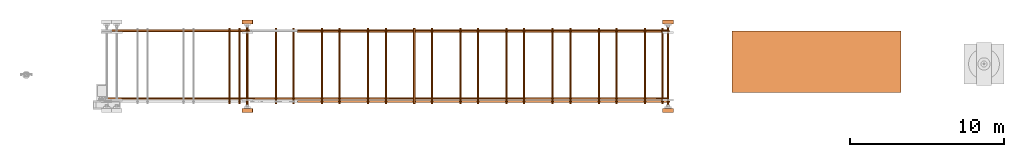
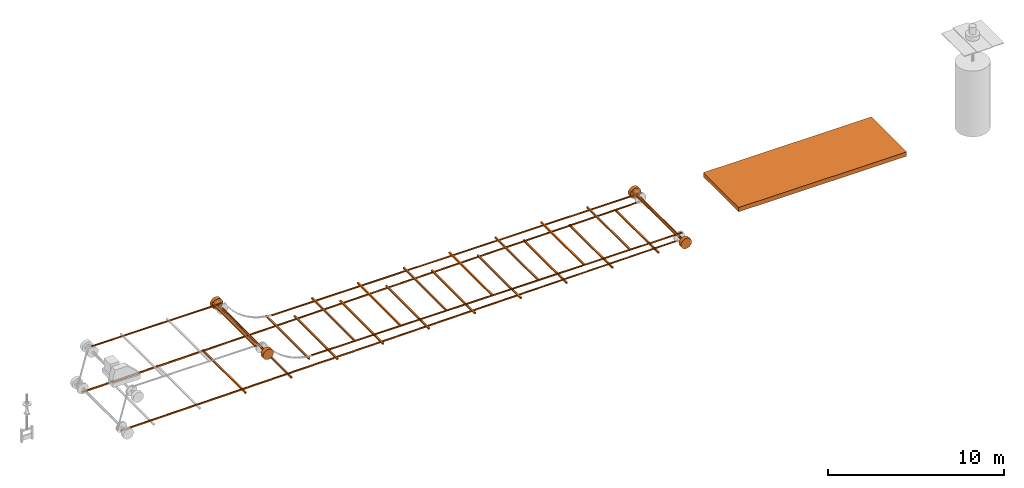
# One storey, part 2 of 6: 39 proxies.
"""IFC2X3 building model written with IfcOpenShell, lengths in millimetres."""

from ifc_helpers import new_model, entity, si_unit, converted_unit, direction, frame, origin_with_axes, origin_2d_with_axis, place, context, project, spatial, polyline, rectangle, circle, outline, extrude, source, transform, mapped, element, save


model = new_model("IFC2X3")

# Units and contexts
model_context = context("Model", 3, precision=1e-05, world=origin_with_axes(), true_north=direction((0.0, 1.0)))
ifc_project = project(units=[si_unit("LENGTHUNIT", "METRE", prefix="MILLI"), si_unit("AREAUNIT", "SQUARE_METRE"), si_unit("VOLUMEUNIT", "CUBIC_METRE"), converted_unit("PLANEANGLEUNIT", "DEGREE", entity("IfcPlaneAngleMeasure", 0.017453293), si_unit("PLANEANGLEUNIT", "RADIAN"), dimensions=[0, 0, 0, 0, 0, 0, 0]), si_unit("SOLIDANGLEUNIT", "STERADIAN"), si_unit("MASSUNIT", "GRAM"), si_unit("TIMEUNIT", "SECOND"), si_unit("THERMODYNAMICTEMPERATUREUNIT", "DEGREE_CELSIUS"), si_unit("LUMINOUSINTENSITYUNIT", "LUMEN")], contexts=[model_context])

# Site, building, storey
site_placement = place(None, origin_with_axes())
site = spatial("IfcSite", under=ifc_project, at=site_placement, CompositionType="ELEMENT")
building_placement = place(site_placement, origin_with_axes())
building = spatial("IfcBuilding", under=site, at=building_placement, Name="Default Building", CompositionType="ELEMENT")
storey_placement = place(building_placement, frame((0.0, 0.0, 16000.0), z_axis=(0.0, 0.0, 1.0), x_axis=(1.0, 0.0, 0.0)))
storey = spatial("IfcBuildingStorey", under=building, at=storey_placement, Name="3FL", CompositionType="ELEMENT", Elevation=16000.0)

# Proxies
shared_shape_1 = source(origin_with_axes(), model_context, "Body", "SweptSolid", [
    extrude(circle(Radius=350.0, at=origin_2d_with_axis()), frame((0.0, 0.0, 0.0), z_axis=(-4.43734259186819e-31, -2.95822839457879e-31, 1.0), x_axis=(1.0, 5.91669923873109e-47, 4.43734259186819e-31)), (0.0, 0.0, 1.0), 250.0),
])
proxy_1_placement = place(storey_placement, frame((52876.115417, 20861.795807, 1232.050808), z_axis=(2.22044604925031e-16, 1.0, 1.60814287233912e-16), x_axis=(4.93038065763132e-32, 1.60814287233912e-16, -1.0)))
element("IfcBuildingElementProxy", 1, at=proxy_1_placement, inside=storey, context=model_context, shape_type="MappedRepresentation", body=[
    mapped(shared_shape_1, transform((0.0, 0.0, 0.0))),
])
shared_shape_2 = source(origin_with_axes(), model_context, "Body", "SweptSolid", [
    extrude(outline(polyline([(-12108.725164, -21.26452), (12108.725164, -21.26452), (12108.725164, 21.26452), (-12108.725164, 21.26452), (-12108.725164, -21.26452)])), origin_with_axes(), (0.0, 0.0, 1.0), 100.0),
])
proxy_2_placement = place(storey_placement, frame((40886.390254, 26161.795807, 1528.900333), z_axis=(0.0, -1.0, 0.0), x_axis=(1.0, 0.0, 0.0)))
element("IfcBuildingElementProxy", 2, at=proxy_2_placement, inside=storey, context=model_context, shape_type="MappedRepresentation", body=[
    mapped(shared_shape_2, transform((0.0, 0.0, 0.0))),
])
shared_shape_3 = source(origin_with_axes(), model_context, "Body", "SweptSolid", [
    extrude(rectangle(XDim=100.0, YDim=4900.0, at=origin_2d_with_axis()), origin_with_axes(), (0.0, 0.0, 1.0), 100.0),
])
proxy_3_placement = place(storey_placement, frame((52526.115454, 23861.796014, 1582.050808), z_axis=(0.0, 0.0, 1.0), x_axis=(1.0, 0.0, 0.0)))
element("IfcBuildingElementProxy", 3, at=proxy_3_placement, inside=storey, context=model_context, shape_type="MappedRepresentation", body=[
    mapped(shared_shape_3, transform((0.0, 0.0, 0.0))),
])
shared_shape_4 = source(origin_with_axes(), model_context, "Body", "SweptSolid", [
    extrude(outline(polyline([(-18245.397829, -225.029041), (18254.602171, 190.177299), (18254.602171, 225.029041), (-18254.602171, -164.882935), (-18245.397829, -225.029041)])), origin_with_axes(), (0.0, 0.0, 1.0), 100.0),
])
proxy_4_placement = place(storey_placement, frame((34621.513247, 21811.795807, 711.550808), z_axis=(0.0, -1.0, 0.0), x_axis=(1.0, 0.0, 0.0)))
element("IfcBuildingElementProxy", 4, at=proxy_4_placement, inside=storey, context=model_context, shape_type="MappedRepresentation", body=[
    mapped(shared_shape_4, transform((0.0, 0.0, 0.0))),
])
shared_shape_5 = source(origin_with_axes(), model_context, "Body", "SweptSolid", [
    extrude(rectangle(XDim=100.0, YDim=4900.0, at=origin_2d_with_axis()), origin_with_axes(), (0.0, 0.0, 1.0), 100.0),
])
proxy_5_placement = place(storey_placement, frame((49526.115454, 23861.796014, 1582.050808), z_axis=(0.0, 0.0, 1.0), x_axis=(1.0, 0.0, 0.0)))
element("IfcBuildingElementProxy", 5, at=proxy_5_placement, inside=storey, context=model_context, shape_type="MappedRepresentation", body=[
    mapped(shared_shape_5, transform((0.0, 0.0, 0.0))),
])
shared_shape_6 = source(origin_with_axes(), model_context, "Body", "SweptSolid", [
    extrude(rectangle(XDim=100.0, YDim=4900.0, at=origin_2d_with_axis()), origin_with_axes(), (0.0, 0.0, 1.0), 100.0),
])
proxy_6_placement = place(storey_placement, frame((46526.115454, 23861.796014, 1582.050808), z_axis=(0.0, 0.0, 1.0), x_axis=(1.0, 0.0, 0.0)))
element("IfcBuildingElementProxy", 6, at=proxy_6_placement, inside=storey, context=model_context, shape_type="MappedRepresentation", body=[
    mapped(shared_shape_6, transform((0.0, 0.0, 0.0))),
])
shared_shape_7 = source(origin_with_axes(), model_context, "Body", "SweptSolid", [
    extrude(rectangle(XDim=100.0, YDim=4900.0, at=origin_2d_with_axis()), origin_with_axes(), (0.0, 0.0, 1.0), 100.0),
])
proxy_7_placement = place(storey_placement, frame((43526.115454, 23861.796014, 1582.050808), z_axis=(0.0, 0.0, 1.0), x_axis=(1.0, 0.0, 0.0)))
element("IfcBuildingElementProxy", 7, at=proxy_7_placement, inside=storey, context=model_context, shape_type="MappedRepresentation", body=[
    mapped(shared_shape_7, transform((0.0, 0.0, 0.0))),
])
shared_shape_8 = source(origin_with_axes(), model_context, "Body", "SweptSolid", [
    extrude(rectangle(XDim=100.0, YDim=4900.0, at=origin_2d_with_axis()), origin_with_axes(), (0.0, 0.0, 1.0), 100.0),
])
proxy_8_placement = place(storey_placement, frame((40526.115454, 23861.796014, 1582.050808), z_axis=(0.0, 0.0, 1.0), x_axis=(1.0, 0.0, 0.0)))
element("IfcBuildingElementProxy", 8, at=proxy_8_placement, inside=storey, context=model_context, shape_type="MappedRepresentation", body=[
    mapped(shared_shape_8, transform((0.0, 0.0, 0.0))),
])
shared_shape_9 = source(origin_with_axes(), model_context, "Body", "SweptSolid", [
    extrude(rectangle(XDim=100.0, YDim=4900.0, at=origin_2d_with_axis()), origin_with_axes(), (0.0, 0.0, 1.0), 100.0),
])
proxy_9_placement = place(storey_placement, frame((37526.115454, 23861.796014, 1582.050808), z_axis=(0.0, 0.0, 1.0), x_axis=(1.0, 0.0, 0.0)))
element("IfcBuildingElementProxy", 9, at=proxy_9_placement, inside=storey, context=model_context, shape_type="MappedRepresentation", body=[
    mapped(shared_shape_9, transform((0.0, 0.0, 0.0))),
])
shared_shape_10 = source(origin_with_axes(), model_context, "Body", "SweptSolid", [
    extrude(rectangle(XDim=100.0, YDim=4900.0, at=origin_2d_with_axis()), origin_with_axes(), (0.0, 0.0, 1.0), 100.0),
])
proxy_10_placement = place(storey_placement, frame((34526.115454, 23861.796014, 1582.050808), z_axis=(0.0, 0.0, 1.0), x_axis=(1.0, 0.0, 0.0)))
element("IfcBuildingElementProxy", 10, at=proxy_10_placement, inside=storey, context=model_context, shape_type="MappedRepresentation", body=[
    mapped(shared_shape_10, transform((0.0, 0.0, 0.0))),
])
shared_shape_11 = source(origin_with_axes(), model_context, "Body", "SweptSolid", [
    extrude(rectangle(XDim=100.0, YDim=4900.0, at=origin_2d_with_axis()), origin_with_axes(), (0.0, 0.0, 1.0), 100.0),
])
proxy_11_placement = place(storey_placement, frame((31526.115454, 23861.796014, 1582.050808), z_axis=(0.0, 0.0, 1.0), x_axis=(1.0, 0.0, 0.0)))
element("IfcBuildingElementProxy", 11, at=proxy_11_placement, inside=storey, context=model_context, shape_type="MappedRepresentation", body=[
    mapped(shared_shape_11, transform((0.0, 0.0, 0.0))),
])
shared_shape_12 = source(origin_with_axes(), model_context, "Body", "SweptSolid", [
    extrude(rectangle(XDim=100.0, YDim=4900.0, at=origin_2d_with_axis()), origin_with_axes(), (0.0, 0.0, 1.0), 100.0),
])
proxy_12_placement = place(storey_placement, frame((28526.115454, 23861.796014, 1399.050808), z_axis=(0.0, 0.0, 1.0), x_axis=(1.0, 0.0, 0.0)))
element("IfcBuildingElementProxy", 12, at=proxy_12_placement, inside=storey, context=model_context, shape_type="MappedRepresentation", body=[
    mapped(shared_shape_12, transform((0.0, 0.0, 0.0))),
])
shared_shape_13 = source(origin_with_axes(), model_context, "Body", "SweptSolid", [
    extrude(rectangle(XDim=100.0, YDim=4900.0, at=origin_2d_with_axis()), origin_with_axes(), (0.0, 0.0, 1.0), 100.0),
])
proxy_13_placement = place(storey_placement, frame((51376.115454, 23861.796014, 743.200808), z_axis=(0.0, 0.0, 1.0), x_axis=(1.0, 0.0, 0.0)))
element("IfcBuildingElementProxy", 13, at=proxy_13_placement, inside=storey, context=model_context, shape_type="MappedRepresentation", body=[
    mapped(shared_shape_13, transform((0.0, 0.0, 0.0))),
])
shared_shape_14 = source(origin_with_axes(), model_context, "Body", "SweptSolid", [
    extrude(rectangle(XDim=100.0, YDim=4900.0, at=origin_2d_with_axis()), origin_with_axes(), (0.0, 0.0, 1.0), 100.0),
])
proxy_14_placement = place(storey_placement, frame((48376.115454, 23861.796014, 743.200808), z_axis=(0.0, 0.0, 1.0), x_axis=(1.0, 0.0, 0.0)))
element("IfcBuildingElementProxy", 14, at=proxy_14_placement, inside=storey, context=model_context, shape_type="MappedRepresentation", body=[
    mapped(shared_shape_14, transform((0.0, 0.0, 0.0))),
])
shared_shape_15 = source(origin_with_axes(), model_context, "Body", "SweptSolid", [
    extrude(rectangle(XDim=100.0, YDim=4900.0, at=origin_2d_with_axis()), origin_with_axes(), (0.0, 0.0, 1.0), 100.0),
])
proxy_15_placement = place(storey_placement, frame((45376.115454, 23861.796014, 743.200808), z_axis=(0.0, 0.0, 1.0), x_axis=(1.0, 0.0, 0.0)))
element("IfcBuildingElementProxy", 15, at=proxy_15_placement, inside=storey, context=model_context, shape_type="MappedRepresentation", body=[
    mapped(shared_shape_15, transform((0.0, 0.0, 0.0))),
])
shared_shape_16 = source(origin_with_axes(), model_context, "Body", "SweptSolid", [
    extrude(rectangle(XDim=100.0, YDim=4900.0, at=origin_2d_with_axis()), origin_with_axes(), (0.0, 0.0, 1.0), 100.0),
])
proxy_16_placement = place(storey_placement, frame((42376.115454, 23861.796014, 743.200808), z_axis=(0.0, 0.0, 1.0), x_axis=(1.0, 0.0, 0.0)))
element("IfcBuildingElementProxy", 16, at=proxy_16_placement, inside=storey, context=model_context, shape_type="MappedRepresentation", body=[
    mapped(shared_shape_16, transform((0.0, 0.0, 0.0))),
])
shared_shape_17 = source(origin_with_axes(), model_context, "Body", "SweptSolid", [
    extrude(rectangle(XDim=100.0, YDim=4900.0, at=origin_2d_with_axis()), origin_with_axes(), (0.0, 0.0, 1.0), 100.0),
])
proxy_17_placement = place(storey_placement, frame((39376.115454, 23861.796014, 743.200808), z_axis=(0.0, 0.0, 1.0), x_axis=(1.0, 0.0, 0.0)))
element("IfcBuildingElementProxy", 17, at=proxy_17_placement, inside=storey, context=model_context, shape_type="MappedRepresentation", body=[
    mapped(shared_shape_17, transform((0.0, 0.0, 0.0))),
])
shared_shape_18 = source(origin_with_axes(), model_context, "Body", "SweptSolid", [
    extrude(rectangle(XDim=100.0, YDim=4900.0, at=origin_2d_with_axis()), origin_with_axes(), (0.0, 0.0, 1.0), 100.0),
])
proxy_18_placement = place(storey_placement, frame((36376.115454, 23861.796014, 743.200808), z_axis=(0.0, 0.0, 1.0), x_axis=(1.0, 0.0, 0.0)))
element("IfcBuildingElementProxy", 18, at=proxy_18_placement, inside=storey, context=model_context, shape_type="MappedRepresentation", body=[
    mapped(shared_shape_18, transform((0.0, 0.0, 0.0))),
])
shared_shape_19 = source(origin_with_axes(), model_context, "Body", "SweptSolid", [
    extrude(rectangle(XDim=100.0, YDim=4900.0, at=origin_2d_with_axis()), origin_with_axes(), (0.0, 0.0, 1.0), 100.0),
])
proxy_19_placement = place(storey_placement, frame((33376.115454, 23861.796014, 743.200808), z_axis=(0.0, 0.0, 1.0), x_axis=(1.0, 0.0, 0.0)))
element("IfcBuildingElementProxy", 19, at=proxy_19_placement, inside=storey, context=model_context, shape_type="MappedRepresentation", body=[
    mapped(shared_shape_19, transform((0.0, 0.0, 0.0))),
])
shared_shape_20 = source(origin_with_axes(), model_context, "Body", "SweptSolid", [
    extrude(rectangle(XDim=100.0, YDim=4900.0, at=origin_2d_with_axis()), origin_with_axes(), (0.0, 0.0, 1.0), 100.0),
])
proxy_20_placement = place(storey_placement, frame((25026.115454, 23861.796014, 3489.050808), z_axis=(0.0, 0.0, 1.0), x_axis=(1.0, 0.0, 0.0)))
element("IfcBuildingElementProxy", 20, at=proxy_20_placement, inside=storey, context=model_context, shape_type="MappedRepresentation", body=[
    mapped(shared_shape_20, transform((0.0, 0.0, 0.0))),
])
shared_shape_21 = source(origin_with_axes(), model_context, "Body", "SweptSolid", [
    extrude(circle(Radius=350.0, at=origin_2d_with_axis()), frame((0.0, 0.0, 0.0), z_axis=(-4.43734259186819e-31, -2.95822839457879e-31, 1.0), x_axis=(1.0, 5.91669923873109e-47, 4.43734259186819e-31)), (0.0, 0.0, 1.0), 250.0),
])
proxy_21_placement = place(storey_placement, frame((25526.115417, 20861.795807, 3139.050808), z_axis=(2.22044604925031e-16, 1.0, 1.60814287233912e-16), x_axis=(4.93038065763132e-32, 1.60814287233912e-16, -1.0)))
element("IfcBuildingElementProxy", 21, at=proxy_21_placement, inside=storey, context=model_context, shape_type="MappedRepresentation", body=[
    mapped(shared_shape_21, transform((0.0, 0.0, 0.0))),
])
shared_shape_22 = source(origin_with_axes(), model_context, "Body", "SweptSolid", [
    extrude(outline(polyline([(-12108.725164, -21.26452), (12108.725164, -21.26452), (12108.725164, 21.26452), (-12108.725164, 21.26452), (-12108.725164, -21.26452)])), origin_with_axes(), (0.0, 0.0, 1.0), 100.0),
])
proxy_22_placement = place(storey_placement, frame((40886.390254, 21611.795807, 1528.900333), z_axis=(0.0, -1.0, 0.0), x_axis=(1.0, 0.0, 0.0)))
element("IfcBuildingElementProxy", 22, at=proxy_22_placement, inside=storey, context=model_context, shape_type="MappedRepresentation", body=[
    mapped(shared_shape_22, transform((0.0, 0.0, 0.0))),
])
shared_shape_23 = source(origin_with_axes(), model_context, "Body", "SweptSolid", [
    extrude(outline(polyline([(-18245.397829, -225.029041), (18254.602171, 190.177299), (18254.602171, 225.029041), (-18254.602171, -164.882935), (-18245.397829, -225.029041)])), origin_with_axes(), (0.0, 0.0, 1.0), 100.0),
])
proxy_23_placement = place(storey_placement, frame((34621.513247, 26211.795807, 711.550808), z_axis=(0.0, -1.0, 0.0), x_axis=(1.0, 0.0, 0.0)))
element("IfcBuildingElementProxy", 23, at=proxy_23_placement, inside=storey, context=model_context, shape_type="MappedRepresentation", body=[
    mapped(shared_shape_23, transform((0.0, 0.0, 0.0))),
])
shared_shape_24 = source(origin_with_axes(), model_context, "Body", "SweptSolid", [
    extrude(outline(polyline([(-4250.0, -21.26452), (4250.0, -21.26452), (4250.0, 21.26452), (-4250.0, 21.26452), (-4250.0, -21.26452)])), origin_with_axes(), (0.0, 0.0, 1.0), 100.0),
])
proxy_24_placement = place(storey_placement, frame((21276.115417, 26211.795807, 3467.786287), z_axis=(0.0, -1.0, 0.0), x_axis=(1.0, 0.0, 0.0)))
element("IfcBuildingElementProxy", 24, at=proxy_24_placement, inside=storey, context=model_context, shape_type="MappedRepresentation", body=[
    mapped(shared_shape_24, transform((0.0, 0.0, 0.0))),
])
shared_shape_25 = source(origin_with_axes(), model_context, "Body", "SweptSolid", [
    extrude(circle(Radius=350.0, at=origin_2d_with_axis()), frame((0.0, 0.0, 0.0), z_axis=(-4.43734259186819e-31, -2.95822839457879e-31, 1.0), x_axis=(1.0, 5.91669923873109e-47, 4.43734259186819e-31)), (0.0, 0.0, 1.0), 250.0),
])
proxy_25_placement = place(storey_placement, frame((25526.115417, 26611.795807, 3139.050808), z_axis=(2.22044604925031e-16, 1.0, 1.60814287233912e-16), x_axis=(4.93038065763132e-32, 1.60814287233912e-16, -1.0)))
element("IfcBuildingElementProxy", 25, at=proxy_25_placement, inside=storey, context=model_context, shape_type="MappedRepresentation", body=[
    mapped(shared_shape_25, transform((0.0, 0.0, 0.0))),
])
shared_shape_26 = source(origin_with_axes(), model_context, "Body", "SweptSolid", [
    extrude(circle(Radius=75.0, at=origin_2d_with_axis()), frame((0.0, 0.0, 0.0), z_axis=(-4.43734259186819e-31, -2.95822839457879e-31, 1.0), x_axis=(1.0, 5.91669923873109e-47, 4.43734259186819e-31)), (0.0, 0.0, 1.0), 5050.0),
])
proxy_26_placement = place(storey_placement, frame((25526.115417, 21336.795807, 3139.050808), z_axis=(2.22044604925031e-16, 1.0, 1.60814287233912e-16), x_axis=(4.93038065763132e-32, 1.60814287233912e-16, -1.0)))
element("IfcBuildingElementProxy", 26, at=proxy_26_placement, inside=storey, context=model_context, shape_type="MappedRepresentation", body=[
    mapped(shared_shape_26, transform((0.0, 0.0, 0.0))),
])
shared_shape_27 = source(origin_with_axes(), model_context, "Body", "SweptSolid", [
    extrude(rectangle(XDim=100.0, YDim=4900.0, at=origin_2d_with_axis()), origin_with_axes(), (0.0, 0.0, 1.0), 100.0),
])
proxy_27_placement = place(storey_placement, frame((27376.115454, 23861.796014, 505.200808), z_axis=(0.0, 0.0, 1.0), x_axis=(1.0, 0.0, 0.0)))
element("IfcBuildingElementProxy", 27, at=proxy_27_placement, inside=storey, context=model_context, shape_type="MappedRepresentation", body=[
    mapped(shared_shape_27, transform((0.0, 0.0, 0.0))),
])
shared_shape_28 = source(origin_with_axes(), model_context, "Body", "SweptSolid", [
    extrude(rectangle(XDim=100.0, YDim=4900.0, at=origin_2d_with_axis()), origin_with_axes(), (0.0, 0.0, 1.0), 100.0),
])
proxy_28_placement = place(storey_placement, frame((24376.115454, 23861.796014, 485.200808), z_axis=(0.0, 0.0, 1.0), x_axis=(1.0, 0.0, 0.0)))
element("IfcBuildingElementProxy", 28, at=proxy_28_placement, inside=storey, context=model_context, shape_type="MappedRepresentation", body=[
    mapped(shared_shape_28, transform((0.0, 0.0, 0.0))),
])
shared_shape_29 = source(origin_with_axes(), model_context, "Body", "SweptSolid", [
    extrude(circle(Radius=75.0, at=origin_2d_with_axis()), frame((0.0, 0.0, 0.0), z_axis=(-4.43734259186819e-31, -2.95822839457879e-31, 1.0), x_axis=(1.0, 5.91669923873109e-47, 4.43734259186819e-31)), (0.0, 0.0, 1.0), 5050.0),
])
proxy_29_placement = place(storey_placement, frame((52876.115417, 21336.795807, 1232.050808), z_axis=(2.22044604925031e-16, 1.0, 1.60814287233912e-16), x_axis=(4.93038065763132e-32, 1.60814287233912e-16, -1.0)))
element("IfcBuildingElementProxy", 29, at=proxy_29_placement, inside=storey, context=model_context, shape_type="MappedRepresentation", body=[
    mapped(shared_shape_29, transform((0.0, 0.0, 0.0))),
])
shared_shape_30 = source(origin_with_axes(), model_context, "Body", "SweptSolid", [
    extrude(circle(Radius=350.0, at=origin_2d_with_axis()), frame((0.0, 0.0, 0.0), z_axis=(-4.43734259186819e-31, -2.95822839457879e-31, 1.0), x_axis=(1.0, 5.91669923873109e-47, 4.43734259186819e-31)), (0.0, 0.0, 1.0), 250.0),
])
proxy_30_placement = place(storey_placement, frame((52876.115417, 26611.795807, 1232.050808), z_axis=(2.22044604925031e-16, 1.0, 1.60814287233912e-16), x_axis=(4.93038065763132e-32, 1.60814287233912e-16, -1.0)))
element("IfcBuildingElementProxy", 30, at=proxy_30_placement, inside=storey, context=model_context, shape_type="MappedRepresentation", body=[
    mapped(shared_shape_30, transform((0.0, 0.0, 0.0))),
])
shared_shape_31 = source(origin_with_axes(), model_context, "Body", "SweptSolid", [
    extrude(rectangle(XDim=100.0, YDim=4900.0, at=origin_2d_with_axis()), origin_with_axes(), (0.0, 0.0, 1.0), 100.0),
])
proxy_31_placement = place(storey_placement, frame((30376.115454, 23861.796014, 743.200808), z_axis=(0.0, 0.0, 1.0), x_axis=(1.0, 0.0, 0.0)))
element("IfcBuildingElementProxy", 31, at=proxy_31_placement, inside=storey, context=model_context, shape_type="MappedRepresentation", body=[
    mapped(shared_shape_31, transform((0.0, 0.0, 0.0))),
])
shared_shape_32 = source(origin_with_axes(), model_context, "Body", "SweptSolid", [
    extrude(circle(Radius=350.0, at=origin_2d_with_axis()), frame((0.0, 0.0, 0.0), z_axis=(-4.43734259186819e-31, -2.95822839457879e-31, 1.0), x_axis=(1.0, 5.91669923873109e-47, 4.43734259186819e-31)), (0.0, 0.0, 1.0), 250.0),
])
proxy_32_placement = place(storey_placement, frame((25526.115417, 20861.795807, 3139.050808), z_axis=(2.22044604925031e-16, 1.0, 1.60814287233912e-16), x_axis=(4.93038065763132e-32, 1.60814287233912e-16, -1.0)))
element("IfcBuildingElementProxy", 32, at=proxy_32_placement, inside=storey, context=model_context, shape_type="MappedRepresentation", body=[
    mapped(shared_shape_32, transform((0.0, 0.0, 0.0))),
])
shared_shape_33 = source(origin_with_axes(), model_context, "Body", "SweptSolid", [
    extrude(circle(Radius=350.0, at=origin_2d_with_axis()), frame((0.0, 0.0, 0.0), z_axis=(-4.43734259186819e-31, -2.95822839457879e-31, 1.0), x_axis=(1.0, 5.91669923873109e-47, 4.43734259186819e-31)), (0.0, 0.0, 1.0), 250.0),
])
proxy_33_placement = place(storey_placement, frame((52876.115417, 20861.795807, 1232.050808), z_axis=(2.22044604925031e-16, 1.0, 1.60814287233912e-16), x_axis=(4.93038065763132e-32, 1.60814287233912e-16, -1.0)))
element("IfcBuildingElementProxy", 33, at=proxy_33_placement, inside=storey, context=model_context, shape_type="MappedRepresentation", body=[
    mapped(shared_shape_33, transform((0.0, 0.0, 0.0))),
])
shared_shape_34 = source(origin_with_axes(), model_context, "Body", "SweptSolid", [
    extrude(outline(polyline([(-4250.0, -21.26452), (4250.0, -21.26452), (4250.0, 21.26452), (-4250.0, 21.26452), (-4250.0, -21.26452)])), origin_with_axes(), (0.0, 0.0, 1.0), 100.0),
])
proxy_34_placement = place(storey_placement, frame((21276.115417, 26211.795807, 3467.786287), z_axis=(0.0, -1.0, 0.0), x_axis=(1.0, 0.0, 0.0)))
element("IfcBuildingElementProxy", 34, at=proxy_34_placement, inside=storey, context=model_context, shape_type="MappedRepresentation", body=[
    mapped(shared_shape_34, transform((0.0, 0.0, 0.0))),
])
shared_shape_35 = source(origin_with_axes(), model_context, "Body", "SweptSolid", [
    extrude(circle(Radius=350.0, at=origin_2d_with_axis()), frame((0.0, 0.0, 0.0), z_axis=(-4.43734259186819e-31, -2.95822839457879e-31, 1.0), x_axis=(1.0, 5.91669923873109e-47, 4.43734259186819e-31)), (0.0, 0.0, 1.0), 250.0),
])
proxy_35_placement = place(storey_placement, frame((25526.115417, 26611.795807, 3139.050808), z_axis=(2.22044604925031e-16, 1.0, 1.60814287233912e-16), x_axis=(4.93038065763132e-32, 1.60814287233912e-16, -1.0)))
element("IfcBuildingElementProxy", 35, at=proxy_35_placement, inside=storey, context=model_context, shape_type="MappedRepresentation", body=[
    mapped(shared_shape_35, transform((0.0, 0.0, 0.0))),
])
shared_shape_36 = source(origin_with_axes(), model_context, "Body", "SweptSolid", [
    extrude(circle(Radius=75.0, at=origin_2d_with_axis()), frame((0.0, 0.0, 0.0), z_axis=(-4.43734259186819e-31, -2.95822839457879e-31, 1.0), x_axis=(1.0, 5.91669923873109e-47, 4.43734259186819e-31)), (0.0, 0.0, 1.0), 5050.0),
])
proxy_36_placement = place(storey_placement, frame((25526.115417, 21336.795807, 3139.050808), z_axis=(2.22044604925031e-16, 1.0, 1.60814287233912e-16), x_axis=(4.93038065763132e-32, 1.60814287233912e-16, -1.0)))
element("IfcBuildingElementProxy", 36, at=proxy_36_placement, inside=storey, context=model_context, shape_type="MappedRepresentation", body=[
    mapped(shared_shape_36, transform((0.0, 0.0, 0.0))),
])
shared_shape_37 = source(origin_with_axes(), model_context, "Body", "SweptSolid", [
    extrude(circle(Radius=75.0, at=origin_2d_with_axis()), frame((0.0, 0.0, 0.0), z_axis=(-4.43734259186819e-31, -2.95822839457879e-31, 1.0), x_axis=(1.0, 5.91669923873109e-47, 4.43734259186819e-31)), (0.0, 0.0, 1.0), 5050.0),
])
proxy_37_placement = place(storey_placement, frame((52876.115417, 21336.795807, 1232.050808), z_axis=(2.22044604925031e-16, 1.0, 1.60814287233912e-16), x_axis=(4.93038065763132e-32, 1.60814287233912e-16, -1.0)))
element("IfcBuildingElementProxy", 37, at=proxy_37_placement, inside=storey, context=model_context, shape_type="MappedRepresentation", body=[
    mapped(shared_shape_37, transform((0.0, 0.0, 0.0))),
])
shared_shape_38 = source(origin_with_axes(), model_context, "Body", "SweptSolid", [
    extrude(circle(Radius=350.0, at=origin_2d_with_axis()), frame((0.0, 0.0, 0.0), z_axis=(-4.43734259186819e-31, -2.95822839457879e-31, 1.0), x_axis=(1.0, 5.91669923873109e-47, 4.43734259186819e-31)), (0.0, 0.0, 1.0), 250.0),
])
proxy_38_placement = place(storey_placement, frame((52876.115417, 26611.795807, 1232.050808), z_axis=(2.22044604925031e-16, 1.0, 1.60814287233912e-16), x_axis=(4.93038065763132e-32, 1.60814287233912e-16, -1.0)))
element("IfcBuildingElementProxy", 38, at=proxy_38_placement, inside=storey, context=model_context, shape_type="MappedRepresentation", body=[
    mapped(shared_shape_38, transform((0.0, 0.0, 0.0))),
])
shared_shape_39 = source(origin_with_axes(), model_context, "Body", "SweptSolid", [
    extrude(rectangle(XDim=11000.0, YDim=4000.0, at=origin_2d_with_axis()), origin_with_axes(), (0.0, 0.0, 1.0), 300.0),
])
proxy_39_placement = place(storey_placement, frame((62536.680497, 24139.865875, 1186.474067), z_axis=(0.0, 0.0, 1.0), x_axis=(1.0, 0.0, 0.0)))
element("IfcBuildingElementProxy", 39, at=proxy_39_placement, inside=storey, context=model_context, shape_type="MappedRepresentation", body=[
    mapped(shared_shape_39, transform((0.0, 0.0, 0.0))),
])

save(model, "model.ifc")
